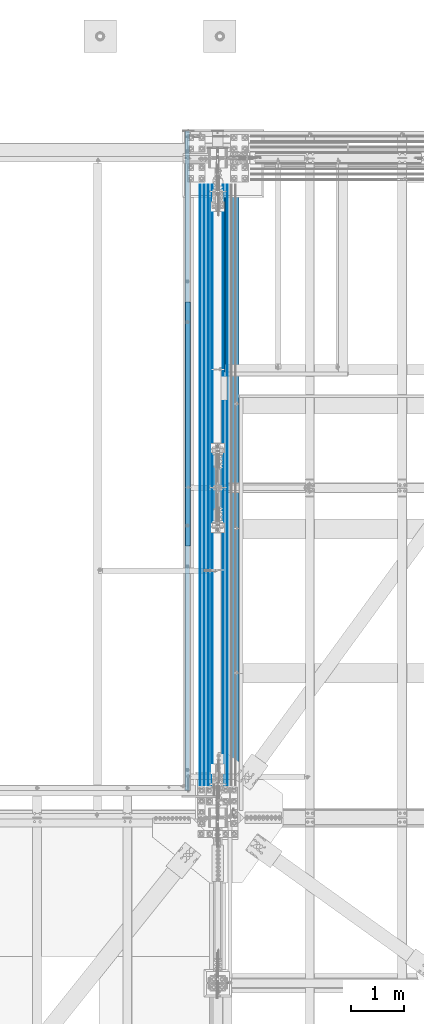
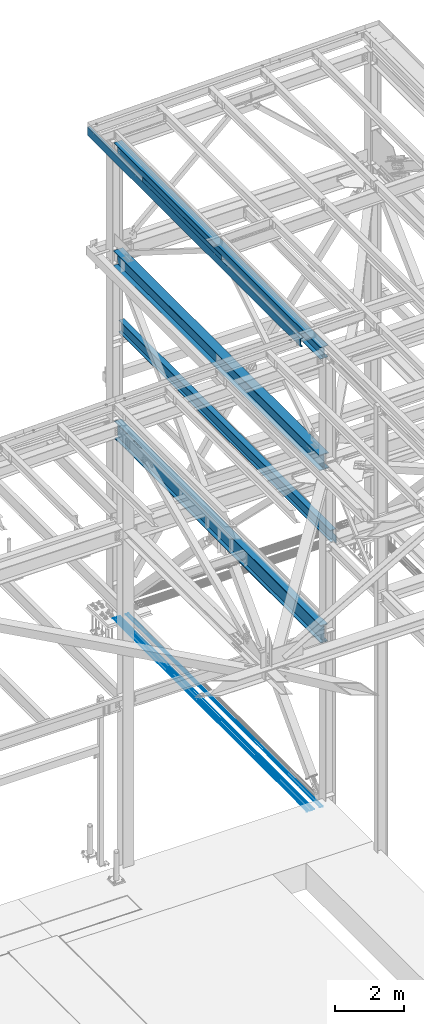
# One storey, part 1938 of 3843: 12 beams, 11 elements without a shape of their own.
"""IFC2X3 building model written with IfcOpenShell, lengths in millimetres."""

from ifc_helpers import new_model, si_unit, frame, origin_with_axes, place, context, subcontext, project, spatial, faceted_brep, material, type_object, element, aggregate, save


model = new_model("IFC2X3")

# Units and contexts
model_context = context("Model", 3, precision=1e-05, world=origin_with_axes())
body_context = subcontext(model_context, "Body", "Model", "MODEL_VIEW")
ifc_project = project(units=[si_unit("LENGTHUNIT", "METRE", prefix="MILLI"), si_unit("AREAUNIT", "SQUARE_METRE"), si_unit("VOLUMEUNIT", "CUBIC_METRE"), si_unit("MASSUNIT", "GRAM", prefix="KILO"), si_unit("TIMEUNIT", "SECOND"), si_unit("PLANEANGLEUNIT", "RADIAN"), si_unit("SOLIDANGLEUNIT", "STERADIAN"), si_unit("THERMODYNAMICTEMPERATUREUNIT", "DEGREE_CELSIUS"), si_unit("LUMINOUSINTENSITYUNIT", "LUMEN")], contexts=[model_context])

# Site, building, storey
site_placement = place(None, origin_with_axes())
site = spatial("IfcSite", under=ifc_project, at=site_placement, CompositionType="ELEMENT")
building_placement = place(site_placement, origin_with_axes())
building = spatial("IfcBuilding", under=site, at=building_placement, Name="Undefined", CompositionType="ELEMENT")
storey_placement = place(building_placement, origin_with_axes())
storey = spatial("IfcBuildingStorey", under=building, at=storey_placement, Name="Undefined", CompositionType="ELEMENT", Elevation=0.0)

# Assembly, beam
assembly_1_placement = place(storey_placement, origin_with_axes())
assembly_1 = element("IfcElementAssembly", 1, at=assembly_1_placement, inside=storey, Name="CHANNEL", AssemblyPlace="NOTDEFINED", PredefinedType="RIGID_FRAME")
ifc_material_1 = material(Name="STEEL/A572-50")
beam_type_1 = type_object("IfcBeamType", Name="C12X20.7", PredefinedType="NOTDEFINED")
beam_1_placement = place(assembly_1_placement, frame((76444.515055577, 92722.7, 46420.6519803869), z_axis=(-0.0211520980073474, 0.0, 0.999776269347241), x_axis=(0.0, 1.0, 0.0)))
beam_1 = element("IfcBeam", 2, at=beam_1_placement, type_object=beam_type_1, material=ifc_material_1, Name="CHANNEL", ObjectType="C12X20.7", context=body_context, shape_type="Brep", body=[
    faceted_brep([(0.0, 38.0999999999985, -152.400000000001), (0.0, 38.0999999999985, 152.400000000001), (12344.4, 38.1000000003551, 152.399999999725), (12344.4, 38.1000000000495, -152.399999999783), (0.0, -38.0999999999985, 152.400000000001), (12344.4, -38.1000000000786, 152.399999999783), (0.0, -38.0999999999985, 146.047460000002), (12344.4, -38.1000000000786, 146.047459999805), (0.0, 30.1624999999985, 134.6749275), (12344.4, 30.1625000002969, 134.674927499764), (0.0, 30.1624999999985, -134.6749275), (12344.4, 30.1625000000204, -134.6749274998), (0.0, -38.0999999999985, -146.047460000002), (12344.4, -38.1000000003696, -146.047459999725), (0.0, -38.0999999999985, -152.400000000001), (12344.4, -38.1000000003842, -152.399999999725)], [[[0, 1, 2, 3]], [[1, 4, 5, 2]], [[4, 6, 7, 5]], [[6, 8, 9, 7]], [[8, 10, 11, 9]], [[10, 12, 13, 11]], [[12, 14, 15, 13]], [[14, 0, 3, 15]], [[5, 7, 9, 11, 13, 15, 3, 2]], [[14, 12, 10, 8, 6, 4, 1, 0]]]),
])

assembly_2_placement = place(storey_placement, origin_with_axes())
assembly_2 = element("IfcElementAssembly", 3, at=assembly_2_placement, inside=storey, Name="REBAR", AssemblyPlace="NOTDEFINED", PredefinedType="RIGID_FRAME")
ifc_material_2 = material(Name="STEEL/A706-60")
beam_type_2 = type_object("IfcBeamType", Name="#10 REBAR", PredefinedType="NOTDEFINED")
beam_2_placement = place(assembly_2_placement, frame((76682.6, 104063.800019533, 29700.5375), z_axis=(0.0, 0.0, 1.0), x_axis=(0.0, -1.0, 0.0)))
beam_2 = element("IfcBeam", 4, at=beam_2_placement, type_object=beam_type_2, material=ifc_material_2, Name="REBAR", ObjectType="#10 REBAR", context=body_context, shape_type="Brep", body=[
    faceted_brep([(0.0, -7.9375, 0.0), (0.0, -5.61266007566883, -5.61266007566883), (11239.5874999941, -5.61266007566883, -5.61266007566883), (11239.5874999941, -7.9375, 0.0), (0.0, 0.0, -7.9375), (11239.5874999941, 0.0, -7.9375), (0.0, 5.61266007566883, -5.61266007566883), (11239.5874999941, 5.61266007566883, -5.61266007566883), (0.0, 7.9375, 0.0), (11239.5874999941, 7.9375, 0.0), (0.0, 5.61266007566883, 5.61266007566883), (11239.5874999941, 5.61266007566883, 5.61266007566883), (0.0, 0.0, 7.9375), (11239.5874999941, 0.0, 7.9375), (0.0, -5.61266007566883, 5.61266007566883), (11239.5874999941, -5.61266007566883, 5.61266007566883)], [[[0, 1, 2, 3]], [[1, 4, 5, 2]], [[4, 6, 7, 5]], [[6, 8, 9, 7]], [[8, 10, 11, 9]], [[10, 12, 13, 11]], [[12, 14, 15, 13]], [[14, 0, 3, 15]], [[5, 7, 9, 11, 13, 15, 3, 2]], [[14, 12, 10, 8, 6, 4, 1, 0]]]),
])
aggregate(assembly_2, [beam_2])

assembly_3_placement = place(storey_placement, origin_with_axes())
assembly_3 = element("IfcElementAssembly", 5, at=assembly_3_placement, inside=storey, Name="REBAR", AssemblyPlace="NOTDEFINED", PredefinedType="RIGID_FRAME")
beam_3_placement = place(assembly_3_placement, frame((76758.8, 104063.800019533, 29700.5375), z_axis=(0.0, 0.0, 1.0), x_axis=(0.0, -1.0, 0.0)))
beam_3 = element("IfcBeam", 6, at=beam_3_placement, type_object=beam_type_2, material=ifc_material_2, Name="REBAR", ObjectType="#10 REBAR", context=body_context, shape_type="Brep", body=[
    faceted_brep([(0.0, -7.9375, 0.0), (0.0, -5.61266007566883, -5.61266007566883), (11239.5874999941, -5.61266007566883, -5.61266007566883), (11239.5874999941, -7.9375, 0.0), (0.0, 0.0, -7.9375), (11239.5874999941, 0.0, -7.9375), (0.0, 5.61266007566883, -5.61266007566883), (11239.5874999941, 5.61266007566883, -5.61266007566883), (0.0, 7.9375, 0.0), (11239.5874999941, 7.9375, 0.0), (0.0, 5.61266007566883, 5.61266007566883), (11239.5874999941, 5.61266007566883, 5.61266007566883), (0.0, 0.0, 7.9375), (11239.5874999941, 0.0, 7.9375), (0.0, -5.61266007566883, 5.61266007566883), (11239.5874999941, -5.61266007566883, 5.61266007566883)], [[[0, 1, 2, 3]], [[1, 4, 5, 2]], [[4, 6, 7, 5]], [[6, 8, 9, 7]], [[8, 10, 11, 9]], [[10, 12, 13, 11]], [[12, 14, 15, 13]], [[14, 0, 3, 15]], [[5, 7, 9, 11, 13, 15, 3, 2]], [[14, 12, 10, 8, 6, 4, 1, 0]]]),
])
aggregate(assembly_3, [beam_3])

assembly_4_placement = place(storey_placement, origin_with_axes())
assembly_4 = element("IfcElementAssembly", 7, at=assembly_4_placement, inside=storey, Name="REBAR", AssemblyPlace="NOTDEFINED", PredefinedType="RIGID_FRAME")
beam_4_placement = place(assembly_4_placement, frame((76835.0, 104063.800019533, 29700.5375), z_axis=(0.0, 0.0, 1.0), x_axis=(0.0, -1.0, 0.0)))
beam_4 = element("IfcBeam", 8, at=beam_4_placement, type_object=beam_type_2, material=ifc_material_2, Name="REBAR", ObjectType="#10 REBAR", context=body_context, shape_type="Brep", body=[
    faceted_brep([(0.0, -7.9375, 0.0), (0.0, -5.61266007566883, -5.61266007566883), (11239.5874999941, -5.61266007566883, -5.61266007566883), (11239.5874999941, -7.9375, 0.0), (0.0, 0.0, -7.9375), (11239.5874999941, 0.0, -7.9375), (0.0, 5.61266007566883, -5.61266007566883), (11239.5874999941, 5.61266007566883, -5.61266007566883), (0.0, 7.9375, 0.0), (11239.5874999941, 7.9375, 0.0), (0.0, 5.61266007566883, 5.61266007566883), (11239.5874999941, 5.61266007566883, 5.61266007566883), (0.0, 0.0, 7.9375), (11239.5874999941, 0.0, 7.9375), (0.0, -5.61266007566883, 5.61266007566883), (11239.5874999941, -5.61266007566883, 5.61266007566883)], [[[0, 1, 2, 3]], [[1, 4, 5, 2]], [[4, 6, 7, 5]], [[6, 8, 9, 7]], [[8, 10, 11, 9]], [[10, 12, 13, 11]], [[12, 14, 15, 13]], [[14, 0, 3, 15]], [[5, 7, 9, 11, 13, 15, 3, 2]], [[14, 12, 10, 8, 6, 4, 1, 0]]]),
])
aggregate(assembly_4, [beam_4])

assembly_5_placement = place(storey_placement, origin_with_axes())
assembly_5 = element("IfcElementAssembly", 9, at=assembly_5_placement, inside=storey, Name="REBAR", AssemblyPlace="NOTDEFINED", PredefinedType="RIGID_FRAME")
beam_5_placement = place(assembly_5_placement, frame((76911.2, 104063.800019533, 29700.5375), z_axis=(0.0, 0.0, 1.0), x_axis=(0.0, -1.0, 0.0)))
beam_5 = element("IfcBeam", 10, at=beam_5_placement, type_object=beam_type_2, material=ifc_material_2, Name="REBAR", ObjectType="#10 REBAR", context=body_context, shape_type="Brep", body=[
    faceted_brep([(0.0, -7.9375, 0.0), (0.0, -5.61266007566883, -5.61266007566883), (11239.5874999941, -5.61266007566883, -5.61266007566883), (11239.5874999941, -7.9375, 0.0), (0.0, 0.0, -7.9375), (11239.5874999941, 0.0, -7.9375), (0.0, 5.61266007566883, -5.61266007566883), (11239.5874999941, 5.61266007566883, -5.61266007566883), (0.0, 7.9375, 0.0), (11239.5874999941, 7.9375, 0.0), (0.0, 5.61266007566883, 5.61266007566883), (11239.5874999941, 5.61266007566883, 5.61266007566883), (0.0, 0.0, 7.9375), (11239.5874999941, 0.0, 7.9375), (0.0, -5.61266007566883, 5.61266007566883), (11239.5874999941, -5.61266007566883, 5.61266007566883)], [[[0, 1, 2, 3]], [[1, 4, 5, 2]], [[4, 6, 7, 5]], [[6, 8, 9, 7]], [[8, 10, 11, 9]], [[10, 12, 13, 11]], [[12, 14, 15, 13]], [[14, 0, 3, 15]], [[5, 7, 9, 11, 13, 15, 3, 2]], [[14, 12, 10, 8, 6, 4, 1, 0]]]),
])
aggregate(assembly_5, [beam_5])

assembly_6_placement = place(storey_placement, origin_with_axes())
assembly_6 = element("IfcElementAssembly", 11, at=assembly_6_placement, inside=storey, Name="REBAR", AssemblyPlace="NOTDEFINED", PredefinedType="RIGID_FRAME")
beam_6_placement = place(assembly_6_placement, frame((77114.4, 104063.800019533, 29700.5375), z_axis=(0.0, 0.0, 1.0), x_axis=(0.0, -1.0, 0.0)))
beam_6 = element("IfcBeam", 12, at=beam_6_placement, type_object=beam_type_2, material=ifc_material_2, Name="REBAR", ObjectType="#10 REBAR", context=body_context, shape_type="Brep", body=[
    faceted_brep([(0.0, -7.9375, 0.0), (0.0, -5.61266007566883, -5.61266007566883), (11239.5874999941, -5.61266007566883, -5.61266007566883), (11239.5874999941, -7.9375, 0.0), (0.0, 0.0, -7.9375), (11239.5874999941, 0.0, -7.9375), (0.0, 5.61266007566883, -5.61266007566883), (11239.5874999941, 5.61266007566883, -5.61266007566883), (0.0, 7.9375, 0.0), (11239.5874999941, 7.9375, 0.0), (0.0, 5.61266007566883, 5.61266007566883), (11239.5874999941, 5.61266007566883, 5.61266007566883), (0.0, 0.0, 7.9375), (11239.5874999941, 0.0, 7.9375), (0.0, -5.61266007566883, 5.61266007566883), (11239.5874999941, -5.61266007566883, 5.61266007566883)], [[[0, 1, 2, 3]], [[1, 4, 5, 2]], [[4, 6, 7, 5]], [[6, 8, 9, 7]], [[8, 10, 11, 9]], [[10, 12, 13, 11]], [[12, 14, 15, 13]], [[14, 0, 3, 15]], [[5, 7, 9, 11, 13, 15, 3, 2]], [[14, 12, 10, 8, 6, 4, 1, 0]]]),
])
aggregate(assembly_6, [beam_6])

assembly_7_placement = place(storey_placement, origin_with_axes())
assembly_7 = element("IfcElementAssembly", 13, at=assembly_7_placement, inside=storey, Name="REBAR", AssemblyPlace="NOTDEFINED", PredefinedType="RIGID_FRAME")
beam_7_placement = place(assembly_7_placement, frame((77190.6, 104063.800019533, 29700.5375), z_axis=(0.0, 0.0, 1.0), x_axis=(0.0, -1.0, 0.0)))
beam_7 = element("IfcBeam", 14, at=beam_7_placement, type_object=beam_type_2, material=ifc_material_2, Name="REBAR", ObjectType="#10 REBAR", context=body_context, shape_type="Brep", body=[
    faceted_brep([(0.0, -7.9375, 0.0), (0.0, -5.61266007566883, -5.61266007566883), (11239.5874999941, -5.61266007566883, -5.61266007566883), (11239.5874999941, -7.9375, 0.0), (0.0, 0.0, -7.9375), (11239.5874999941, 0.0, -7.9375), (0.0, 5.61266007566883, -5.61266007566883), (11239.5874999941, 5.61266007566883, -5.61266007566883), (0.0, 7.9375, 0.0), (11239.5874999941, 7.9375, 0.0), (0.0, 5.61266007566883, 5.61266007566883), (11239.5874999941, 5.61266007566883, 5.61266007566883), (0.0, 0.0, 7.9375), (11239.5874999941, 0.0, 7.9375), (0.0, -5.61266007566883, 5.61266007566883), (11239.5874999941, -5.61266007566883, 5.61266007566883)], [[[0, 1, 2, 3]], [[1, 4, 5, 2]], [[4, 6, 7, 5]], [[6, 8, 9, 7]], [[8, 10, 11, 9]], [[10, 12, 13, 11]], [[12, 14, 15, 13]], [[14, 0, 3, 15]], [[5, 7, 9, 11, 13, 15, 3, 2]], [[14, 12, 10, 8, 6, 4, 1, 0]]]),
])
aggregate(assembly_7, [beam_7])

# Beam
ifc_material_3 = material(Name="STEEL/A36")
beam_type_3 = type_object("IfcBeamType", PredefinedType="NOTDEFINED")
beam_8_placement = place(assembly_1_placement, frame((76504.7101110363, 99580.7, 46577.535331714), z_axis=(0.0, -1.0, 0.0), x_axis=(-0.999776270257024, 0.0, -0.0211520550054595)))
beam_8 = element("IfcBeam", 15, at=beam_8_placement, type_object=beam_type_3, material=ifc_material_3, Name="BENT_PLATE", context=body_context, shape_type="Brep", body=[
    faceted_brep([(95.2500000062137, -3.17499999998836, 2282.82500004768), (98.4249999528402, -4.28699422627687e-08, 2286.0), (0.0, 0.0, 2286.0), (0.0, -3.17500000000291, 2282.82500004767), (95.2500000080618, -161.924999997093, 2282.82500004768), (98.4249999547465, -161.924999997056, 2286.0), (5.82076609134674e-11, -3.17499999999563, -2286.0), (95.2500015456608, -3.17499999825668, -2286.0), (-4.36557456851006e-11, 3.17499999998836, 2286.0), (-4.36557456851006e-11, 3.17499999998836, -2286.0), (101.600001600964, 3.175000001851, 2286.0), (101.600001600964, 3.175000001851, -2286.0), (101.600000008097, -161.92499999702, 2286.0), (101.600000162842, -161.92499995813, -2286.0), (95.2500001628505, -161.924999902811, -2286.0)], [[[0, 1, 2, 3]], [[4, 5, 1, 0]], [[6, 7, 0, 3]], [[8, 9, 6, 3, 2]], [[9, 8, 10, 11]], [[11, 10, 12, 13]], [[5, 12, 10, 8, 2, 1]], [[7, 14, 4, 0]], [[7, 6, 9, 11, 13, 14]], [[14, 13, 12, 5, 4]]]),
])

aggregate(assembly_1, [beam_8, beam_1])

# Assembly, beam
assembly_8_placement = place(storey_placement, origin_with_axes())
assembly_8 = element("IfcElementAssembly", 16, at=assembly_8_placement, inside=storey, Name="BEAM", AssemblyPlace="NOTDEFINED", PredefinedType="RIGID_FRAME")
ifc_material_4 = material(Name="STEEL/A992")
beam_type_4 = type_object("IfcBeamType", Name="W21X101", PredefinedType="NOTDEFINED")
beam_9_placement = place(assembly_8_placement, frame((77012.8000005026, 92214.7, 42197.3375), z_axis=(0.0, 0.0, 1.0), x_axis=(0.0, 1.0, 0.0)))
beam_9 = element("IfcBeam", 17, at=beam_9_placement, type_object=beam_type_4, material=ifc_material_4, Name="BEAM", ObjectType="W21X101", context=body_context, shape_type="Brep", body=[
    faceted_brep([(201.007348416882, 6.35000000000582, 215.900000000001), (201.007348416882, 6.35000000000582, -215.900000000001), (193.674999999996, -6.35000000000582, -215.900000000001), (193.674999999996, -6.35000000000582, 215.900000000001), (270.487265581483, -6.35000000000036, -215.900000000001), (270.487265581483, 6.35000000000036, -215.900000000001), (275.550430772229, 6.35000000000036, -217.357163726287), (275.550430772229, -6.35000000000036, -217.357163726287), (279.064438807793, 6.35000000000036, -221.282812131343), (279.064438807793, -6.35000000000036, -221.282812131343), (279.954122181924, 6.35000000000036, -226.475829690324), (279.954122181924, -6.35000000000036, -226.475829690324), (277.94726789881, 6.35000000000036, -231.347328818971), (277.94726789881, -6.35000000000036, -231.347328818971), (273.657905435088, 6.35000000000036, -234.406795689014), (273.657905435088, -6.35000000000036, -234.406795689014), (228.27300000003, 6.35000000000036, -250.428), (228.27300000003, -6.35000000000036, -250.428), (205.818807990843, 6.35000000000036, -250.428), (205.818807990843, -6.35000000000036, -250.428), (205.589615981677, 6.35000000000036, -250.824999999997), (205.589615981677, 155.575000000001, -250.824999999997), (193.675000000003, 155.575000000001, -271.462500000001), (193.675000000003, -155.575000000001, -271.462500000001), (205.589615981677, -155.575000000001, -250.824999999997), (205.589615981677, -6.35000000000036, -250.824999999997), (12138.8103840184, 6.35000000000582, -250.824999999997), (12138.8103840184, 155.574999999997, -250.824999999997), (12150.725, 155.574999999997, -271.462500000001), (12150.725, -155.574999999997, -271.462500000001), (12138.8103840184, -155.574999999997, -250.824999999997), (12138.8103840184, -6.35000000000582, -250.824999999997), (12138.5811920092, 6.35000000000582, -250.428), (12138.5811920092, -6.35000000000582, -250.428), (12116.127, 6.35000000000582, -250.428), (12116.127, -6.35000000000582, -250.428), (12070.742094565, 6.35000000000582, -234.406795689014), (12070.742094565, -6.35000000000582, -234.406795689014), (12066.4527321013, 6.35000000000582, -231.347328818971), (12066.4527321013, -6.35000000000582, -231.347328818971), (12064.4458778181, 6.35000000000582, -226.475829690324), (12064.4458778181, -6.35000000000582, -226.475829690324), (12065.3355611923, 6.35000000000582, -221.282812131343), (12065.3355611923, -6.35000000000582, -221.282812131343), (12068.8495692278, 6.35000000000582, -217.357163726287), (12068.8495692278, -6.35000000000582, -217.357163726287), (12073.9127344186, 6.35000000000582, -215.900000000001), (12073.9127344186, -6.35000000000582, -215.900000000001), (12143.3926515832, 6.35000000000582, -215.900000000001), (12150.725, -6.35000000000582, -215.900000000001), (12150.725, -6.34999999991851, 215.900000000001), (12143.3926515832, 6.35000000000582, 215.900000000001), (12073.5857344186, 6.35000000000582, 215.900000000001), (12073.5857344186, -6.35000000000582, 215.900000000001), (12068.5225692278, 6.35000000000582, 217.357163726287), (12068.5225692278, -6.35000000000582, 217.357163726287), (12065.0085611923, 6.35000000000582, 221.282812131351), (12065.0085611923, -6.35000000000582, 221.282812131351), (12064.1188778182, 6.35000000000582, 226.475829690324), (12064.1188778182, -6.35000000000582, 226.475829690324), (12066.1257321013, 6.35000000000582, 231.347328818971), (12066.1257321013, -6.35000000000582, 231.347328818971), (12070.415094565, 6.35000000000582, 234.406795689014), (12070.415094565, -6.35000000000582, 234.406795689014), (12115.8, 6.35000000000582, 250.428), (12115.8, -6.35000000000582, 250.428), (12150.725, 6.35000000000582, 250.428), (12150.725, -6.35000000000582, 250.428), (12150.725, 6.35000000000582, 250.824999999997), (12150.725, -6.35000000000582, 250.824999999997), (193.675000000003, 6.35000000000036, 250.824999999997), (193.675000000003, 155.575000000001, 250.824999999997), (12150.725, 155.574999999997, 250.824999999997), (205.589601116109, 155.575000000001, 271.462500000001), (12138.810398884, 155.574999999997, 271.462500000001), (205.589601116109, -155.575000000001, 271.462500000001), (193.675000000003, -155.575000000001, 250.824999999997), (12150.725, -155.574999999997, 250.824999999997), (12138.810398884, -155.574999999997, 271.462500000001), (193.675000000003, -6.35000000000036, 250.824999999997), (193.675000000003, 6.35000000000036, 250.428), (193.675000000003, -6.35000000000036, 250.428), (228.60000000002, 6.35000000000036, 250.428), (228.60000000002, -6.35000000000036, 250.428), (273.984905435093, 6.35000000000036, 234.406795689014), (273.984905435093, -6.35000000000036, 234.406795689014), (278.274267898814, 6.35000000000036, 231.347328818971), (278.274267898814, -6.35000000000036, 231.347328818971), (280.281122181914, 6.35000000000036, 226.475829690324), (280.281122181914, -6.35000000000036, 226.475829690324), (279.391438807783, 6.35000000000036, 221.282812131351), (279.391438807783, -6.35000000000036, 221.282812131351), (275.877430772234, 6.35000000000036, 217.357163726287), (275.877430772234, -6.35000000000036, 217.357163726287), (270.814265581474, 6.35000000000036, 215.900000000001), (270.814265581474, -6.35000000000036, 215.900000000001)], [[[0, 1, 2, 3]], [[4, 5, 6, 7]], [[7, 6, 8, 9]], [[9, 8, 10, 11]], [[11, 10, 12, 13]], [[13, 12, 14, 15]], [[15, 14, 16, 17]], [[17, 16, 18, 19]], [[19, 18, 20, 21, 22, 23, 24, 25]], [[21, 20, 26, 27]], [[22, 21, 27, 28]], [[23, 22, 28, 29]], [[24, 23, 29, 30]], [[25, 24, 30, 31]], [[29, 28, 27, 26, 32, 33, 31, 30]], [[34, 35, 33, 32]], [[35, 34, 36, 37]], [[37, 36, 38, 39]], [[39, 38, 40, 41]], [[41, 40, 42, 43]], [[43, 42, 44, 45]], [[45, 44, 46, 47]], [[47, 46, 48, 49]], [[50, 49, 48, 51]], [[52, 53, 50, 51]], [[53, 52, 54, 55]], [[55, 54, 56, 57]], [[57, 56, 58, 59]], [[59, 58, 60, 61]], [[61, 60, 62, 63]], [[63, 62, 64, 65]], [[65, 64, 66, 67]], [[67, 66, 68, 69]], [[70, 71, 72, 68]], [[71, 73, 74, 72]], [[75, 76, 77, 78]], [[73, 75, 78, 74]], [[77, 69, 68, 72, 74, 78]], [[76, 79, 69, 77]], [[75, 73, 71, 70, 79, 76]], [[80, 81, 79, 70]], [[82, 83, 81, 80]], [[83, 82, 84, 85]], [[85, 84, 86, 87]], [[87, 86, 88, 89]], [[89, 88, 90, 91]], [[91, 90, 92, 93]], [[93, 92, 94, 95]], [[95, 94, 0, 3]], [[4, 7, 9, 11, 13, 15, 17, 19, 25, 31, 33, 35, 37, 39, 41, 43, 45, 47, 49, 50, 53, 55, 57, 59, 61, 63, 65, 67, 69, 79, 81, 83, 85, 87, 89, 91, 93, 95, 3, 2]], [[5, 4, 2, 1]], [[94, 92, 90, 88, 86, 84, 82, 80, 70, 68, 66, 64, 62, 60, 58, 56, 54, 52, 51, 48, 46, 44, 42, 40, 38, 36, 34, 32, 26, 20, 18, 16, 14, 12, 10, 8, 6, 5, 1, 0]]]),
])
aggregate(assembly_8, [beam_9])

assembly_9_placement = place(storey_placement, origin_with_axes())
assembly_9 = element("IfcElementAssembly", 18, at=assembly_9_placement, inside=storey, Name="BEAM", AssemblyPlace="NOTDEFINED", PredefinedType="RIGID_FRAME")
beam_type_5 = type_object("IfcBeamType", Name="W16X67", PredefinedType="NOTDEFINED")
beam_10_placement = place(assembly_9_placement, frame((77012.8, 92214.7, 46065.9270639774), z_axis=(0.0, 0.0, 1.0), x_axis=(0.0, 1.0, 0.0)))
beam_10 = element("IfcBeam", 19, at=beam_10_placement, type_object=beam_type_5, material=ifc_material_4, Name="BEAM", ObjectType="W16X67", context=body_context, shape_type="Brep", body=[
    faceted_brep([(196.849999999977, -130.175000000003, -207.962500000001), (196.849999999977, 130.175000000003, -207.962500000001), (12147.55, 130.175000000003, -207.962500000001), (12147.55, -130.175000000003, -207.962500000001), (196.849999999977, -130.175000000003, -190.5), (196.849999999977, -4.76249999999709, -190.5), (196.849999999977, -4.76249999999709, -154.727500662353), (196.849999999977, -4.76249999999709, 164.252499337643), (196.849999999977, -4.76249999999709, 190.5), (196.849999999977, -130.175000000003, 190.5), (196.849999999977, -130.175000000003, 207.962500000001), (196.849999999977, 130.175000000003, 207.962500000001), (196.849999999977, 130.175000000003, 190.5), (196.849999999977, 4.76249999999709, 190.5), (196.849999999977, 4.76249999999709, -190.5), (196.849999999977, 130.175000000003, -190.5), (12147.55, -130.175000000003, -190.5), (12147.55, -4.76249999999709, -190.5), (12147.55, -4.76249999999709, -154.727500662353), (12147.55, -4.76249999999709, 164.252499337643), (12147.55, -4.76249999999709, 190.5), (12147.55, -130.175000000003, 190.5), (12147.55, -130.175000000003, 207.962500000001), (12147.55, 130.175000000003, 207.962500000001), (12147.55, 130.175000000003, 190.5), (12147.55, 4.76249999999709, 190.5), (12147.55, 4.76249999999709, -190.5), (12147.55, 130.175000000003, -190.5)], [[[0, 1, 2, 3]], [[0, 4, 5, 6, 7, 8, 9, 10, 11, 12, 13, 14, 15, 1]], [[5, 4, 16, 17]], [[8, 7, 6, 5, 17, 18, 19, 20]], [[9, 8, 20, 21]], [[10, 9, 21, 22]], [[11, 10, 22, 23]], [[12, 11, 23, 24]], [[13, 12, 24, 25]], [[14, 13, 25, 26]], [[15, 14, 26, 27]], [[1, 15, 27, 2]], [[26, 25, 24, 23, 22, 21, 20, 19, 18, 17, 16, 3, 2, 27]], [[4, 0, 3, 16]]]),
])
aggregate(assembly_9, [beam_10])

assembly_10_placement = place(storey_placement, origin_with_axes())
assembly_10 = element("IfcElementAssembly", 20, at=assembly_10_placement, inside=storey, Name="BEAM", AssemblyPlace="NOTDEFINED", PredefinedType="RIGID_FRAME")
beam_type_6 = type_object("IfcBeamType", Name="W16X57", PredefinedType="NOTDEFINED")
beam_11_placement = place(assembly_10_placement, frame((77317.6, 92214.7, 39476.3625), z_axis=(0.0, 0.0, 1.0), x_axis=(0.0, 1.0, 0.0)))
beam_11 = element("IfcBeam", 21, at=beam_11_placement, type_object=beam_type_6, material=ifc_material_4, Name="BEAM", ObjectType="W16X57", context=body_context, shape_type="Brep", body=[
    faceted_brep([(196.056250190712, -5.55624999999418, 93.6624999999985), (196.056250190712, 5.55624999999418, 93.6624999999985), (18.2562499999767, 5.55624999999418, 93.6624999999985), (18.2562499999767, -5.55624999999418, 93.6624999999985), (200.916329708751, -5.55624999999418, 94.6292299225897), (200.916329708751, 5.55624999999418, 94.6292299225897), (205.036506176912, -5.55624999999418, 97.3822438230636), (205.036506176912, 5.55624999999418, 97.3822438230636), (207.789520077393, -5.55624999999418, 101.502420291217), (207.789520077393, 5.55624999999418, 101.502420291217), (208.756249999977, -5.55624999999418, 106.362499809264), (208.756249999977, 5.55624999999418, 106.362499809264), (208.756249999977, -90.4875000000029, 207.962500000001), (208.756249999977, 90.4875000000029, 207.962500000001), (208.756249999977, 90.4875000000029, 190.5), (208.756249999977, 5.55624999999418, 190.5), (208.756249999977, -5.55624999999418, 190.5), (208.756249999977, -90.4875000000029, 190.5), (18.2562499999767, -5.55624999999418, -157.162499999999), (18.2562499999767, 5.55624999999418, -157.162499999999), (196.056250190712, 5.55624999999418, -157.162499999999), (196.056250190712, -5.55624999999418, -157.162499999999), (200.916329708751, 5.55624999999418, -158.12922992259), (200.916329708751, -5.55624999999418, -158.12922992259), (205.036506176912, 5.55624999999418, -160.882243823064), (205.036506176912, -5.55624999999418, -160.882243823064), (207.789520077393, 5.55624999999418, -165.002420291217), (207.789520077393, -5.55624999999418, -165.002420291217), (208.756249999977, 5.55624999999418, -169.862499809264), (208.756249999977, -5.55624999999418, -169.862499809264), (12469.8125, 5.55624999999418, -190.5), (12469.8125, 90.4875000000029, -190.5), (208.756249999977, 90.4875000000029, -190.5), (208.756249999977, 5.55624999999418, -190.5), (12469.8125, 90.4875000000029, -207.962500000001), (12469.8125, -90.4875000000029, -207.962500000001), (208.756249999977, -90.4875000000029, -207.962500000001), (208.756249999977, 90.4875000000029, -207.962500000001), (12469.8125, -90.4875000000029, -190.5), (208.756249999977, -90.4875000000029, -190.5), (12469.8125, -5.55624999999418, -190.5), (208.756249999977, -5.55624999999418, -190.5), (12469.8125, 5.55624999999418, 190.5), (12469.8125, 90.4875000000029, 190.5), (12469.8125, 90.4875000000029, 207.962500000001), (12469.8125, -90.4875000000029, 207.962500000001), (12469.8125, -90.4875000000029, 190.5), (12469.8125, -5.55624999999418, 190.5), (18.2562499999767, 5.55624999999418, -136.9375)], [[[0, 1, 2, 3]], [[4, 5, 1, 0]], [[6, 7, 5, 4]], [[8, 9, 7, 6]], [[10, 11, 9, 8]], [[12, 13, 14, 15, 11, 10, 16, 17]], [[18, 19, 20, 21]], [[21, 20, 22, 23]], [[23, 22, 24, 25]], [[25, 24, 26, 27]], [[27, 26, 28, 29]], [[30, 31, 32, 33]], [[34, 35, 36, 37]], [[35, 38, 39, 36]], [[38, 40, 41, 39]], [[29, 28, 33, 32, 37, 36, 39, 41]], [[31, 34, 37, 32]], [[30, 42, 43, 44, 45, 46, 47, 40, 38, 35, 34, 31]], [[46, 45, 12, 17]], [[47, 46, 17, 16]], [[8, 6, 4, 0, 3, 18, 21, 23, 25, 27, 29, 41, 40, 47, 16, 10]], [[48, 19, 18, 3, 2]], [[42, 30, 33, 28, 26, 24, 22, 20, 19, 48, 2, 1, 5, 7, 9, 11, 15]], [[43, 42, 15, 14]], [[44, 43, 14, 13]], [[45, 44, 13, 12]]]),
])
aggregate(assembly_10, [beam_11])

assembly_11_placement = place(storey_placement, origin_with_axes())
assembly_11 = element("IfcElementAssembly", 22, at=assembly_11_placement, inside=storey, Name="BEAM", AssemblyPlace="NOTDEFINED", PredefinedType="RIGID_FRAME")
beam_type_7 = type_object("IfcBeamType", Name="W24X103", PredefinedType="NOTDEFINED")
beam_12_placement = place(assembly_11_placement, frame((77012.8, 92214.7, 36125.15), z_axis=(0.0, 0.0, 1.0), x_axis=(0.0, 1.0, 0.0)))
beam_12 = element("IfcBeam", 23, at=beam_12_placement, type_object=beam_type_7, material=ifc_material_4, Name="BEAM", ObjectType="W24X103", context=body_context, shape_type="Brep", body=[
    faceted_brep([(201.923891969011, -7.14374999998836, 257.175000000003), (193.675000000017, 7.14375000000291, 257.175000000003), (193.675000000017, 7.14375000000291, -257.175000000003), (201.923891969011, -7.14375000000291, -257.175000000003), (283.075688964629, -7.14375000000291, -257.175000000003), (283.075688964629, 7.14375000000291, -257.175000000003), (288.657194039319, 7.14375000000291, -258.981682519952), (288.657194039319, -7.14375000000291, -258.981682519952), (292.121322094099, 7.14375000000291, -263.716354361466), (292.121322094099, -7.14375000000291, -263.716354361466), (292.153935626789, 7.14375000000291, -269.582889709032), (292.153935626789, -7.14375000000291, -269.582889709032), (288.742662500546, 7.14375000000291, -274.35578361994), (288.742662500546, -7.14375000000291, -274.35578361994), (273.886000000013, 7.14375000000291, -285.353000000003), (273.886000000013, -7.14375000000291, -285.353000000003), (208.568799725821, 7.14375000000291, -285.353000000003), (208.568799725821, -7.14375000000291, -285.353000000003), (12136.0604005484, 7.14375000000291, -285.75), (12136.0604005484, 114.300000000003, -285.75), (208.339599451632, 114.300000000003, -285.75), (208.339599451632, 7.14375000000291, -285.75), (12150.725, 114.300000000003, -311.150000000001), (193.675000000017, 114.300000000003, -311.150000000001), (12150.725, -114.300000000003, -311.150000000001), (193.675000000017, -114.300000000003, -311.150000000001), (12136.0604005484, -114.300000000003, -285.75), (208.339599451632, -114.300000000003, -285.75), (208.339599451632, -7.14375000000291, -285.75), (12136.0604005484, -7.14375000000291, -285.75), (12135.8312002742, 7.14375000000291, -285.353000000003), (12135.8312002742, -7.14375000000291, -285.353000000003), (12070.514, 7.14375000000291, -285.353000000003), (12070.514, -7.14375000000291, -285.353000000003), (12055.6573374995, 7.14375000000291, -274.35578361994), (12055.6573374995, -7.14375000000291, -274.35578361994), (12052.2460643733, 7.14375000000291, -269.582889709032), (12052.2460643733, -7.14375000000291, -269.582889709032), (12052.278677906, 7.14375000000291, -263.716354361466), (12052.278677906, -7.14375000000291, -263.716354361466), (12055.7428059607, 7.14375000000291, -258.981682519952), (12055.7428059607, -7.14375000000291, -258.981682519952), (12061.3243110354, 7.14375000000291, -257.175000000003), (12061.3243110354, -7.14375000000291, -257.175000000003), (12150.725, 7.14375000000291, -257.175000000003), (12142.476108031, -7.14375000000291, -257.175000000003), (12150.725, 7.14374999998836, 257.175000000003), (12142.476108031, -7.14375000000291, 257.175000000003), (12062.1603110354, 7.14375000000291, 257.175000000003), (12062.1603110354, -7.14375000000291, 257.175000000003), (12056.5788059607, 7.14375000000291, 258.981682519952), (12056.5788059607, -7.14375000000291, 258.981682519952), (12053.114677906, 7.14375000000291, 263.716354361466), (12053.114677906, -7.14375000000291, 263.716354361466), (12053.0820643733, 7.14375000000291, 269.582889709025), (12053.0820643733, -7.14375000000291, 269.582889709025), (12056.4933374995, 7.14375000000291, 274.35578361994), (12056.4933374995, -7.14375000000291, 274.35578361994), (12071.35, 7.14375000000291, 285.353000000003), (12071.35, -7.14375000000291, 285.353000000003), (12150.725, 7.14375000000291, 285.353000000003), (12150.725, -7.14375000000291, 285.353000000003), (12150.725, 7.14375000000291, 285.75), (12150.725, -7.14375000000291, 285.75), (12150.725, -114.300000000003, 285.75), (12150.725, 114.300000000003, 285.75), (12136.0604127907, 114.300000000003, 311.150000000001), (12136.0604127907, -114.300000000003, 311.150000000001), (193.675000000017, 7.14375000000291, 285.75), (193.675000000017, 114.300000000003, 285.75), (208.339587209368, 114.300000000003, 311.150000000001), (208.339587209368, -114.300000000003, 311.150000000001), (193.675000000017, -114.300000000003, 285.75), (193.675000000017, -7.14375000000291, 285.75), (193.675000000017, 7.14375000000291, 285.353000000003), (193.675000000017, -7.14375000000291, 285.353000000003), (273.050000000017, 7.14375000000291, 285.353000000003), (273.050000000017, -7.14375000000291, 285.353000000003), (287.906662500536, 7.14375000000291, 274.35578361994), (287.906662500536, -7.14375000000291, 274.35578361994), (291.317935626794, 7.14375000000291, 269.582889709025), (291.317935626794, -7.14375000000291, 269.582889709025), (291.285322094089, 7.14375000000291, 263.716354361466), (291.285322094089, -7.14375000000291, 263.716354361466), (287.821194039308, 7.14375000000291, 258.981682519952), (287.821194039308, -7.14375000000291, 258.981682519952), (282.239688964619, 7.14375000000291, 257.175000000003), (282.239688964619, -7.14375000000291, 257.175000000003)], [[[0, 1, 2, 3]], [[4, 5, 6, 7]], [[7, 6, 8, 9]], [[9, 8, 10, 11]], [[11, 10, 12, 13]], [[13, 12, 14, 15]], [[15, 14, 16, 17]], [[18, 19, 20, 21]], [[19, 22, 23, 20]], [[22, 24, 25, 23]], [[24, 26, 27, 25]], [[17, 16, 21, 20, 23, 25, 27, 28]], [[26, 29, 28, 27]], [[24, 22, 19, 18, 30, 31, 29, 26]], [[32, 33, 31, 30]], [[33, 32, 34, 35]], [[35, 34, 36, 37]], [[37, 36, 38, 39]], [[39, 38, 40, 41]], [[41, 40, 42, 43]], [[43, 42, 44, 45]], [[46, 47, 45, 44]], [[48, 49, 47, 46]], [[49, 48, 50, 51]], [[51, 50, 52, 53]], [[53, 52, 54, 55]], [[55, 54, 56, 57]], [[57, 56, 58, 59]], [[59, 58, 60, 61]], [[61, 60, 62, 63]], [[64, 63, 62, 65, 66, 67]], [[65, 62, 68, 69]], [[66, 65, 69, 70]], [[67, 66, 70, 71]], [[64, 67, 71, 72]], [[63, 64, 72, 73]], [[71, 70, 69, 68, 73, 72]], [[74, 75, 73, 68]], [[76, 77, 75, 74]], [[77, 76, 78, 79]], [[79, 78, 80, 81]], [[81, 80, 82, 83]], [[83, 82, 84, 85]], [[85, 84, 86, 87]], [[4, 7, 9, 11, 13, 15, 17, 28, 29, 31, 33, 35, 37, 39, 41, 43, 45, 47, 49, 51, 53, 55, 57, 59, 61, 63, 73, 75, 77, 79, 81, 83, 85, 87, 0, 3]], [[5, 4, 3, 2]], [[86, 84, 82, 80, 78, 76, 74, 68, 62, 60, 58, 56, 54, 52, 50, 48, 46, 44, 42, 40, 38, 36, 34, 32, 30, 18, 21, 16, 14, 12, 10, 8, 6, 5, 2, 1]], [[87, 86, 1, 0]]]),
])
aggregate(assembly_11, [beam_12])

save(model, "model.ifc")
